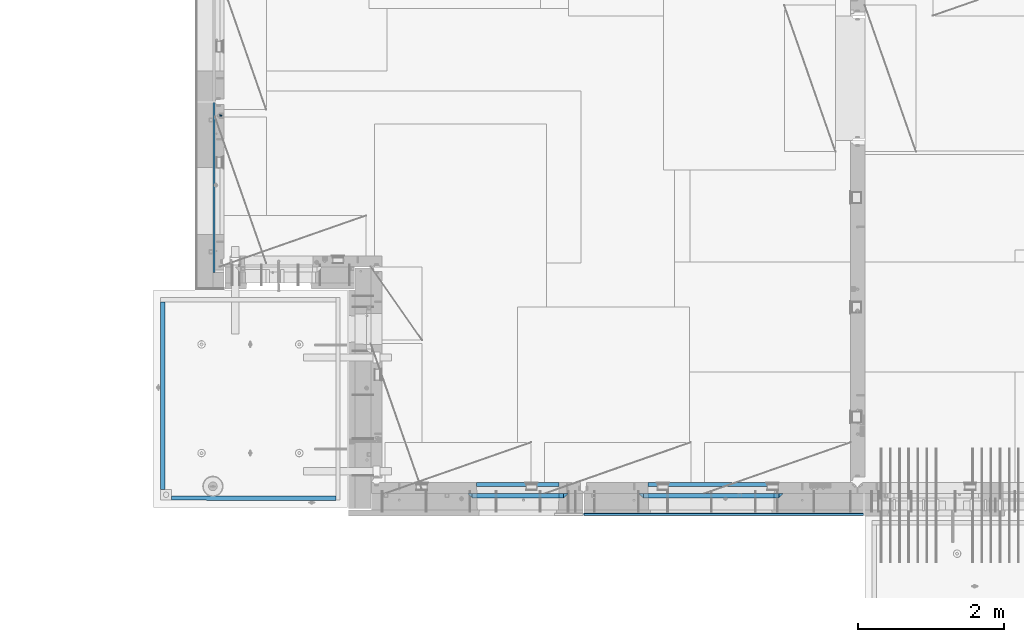
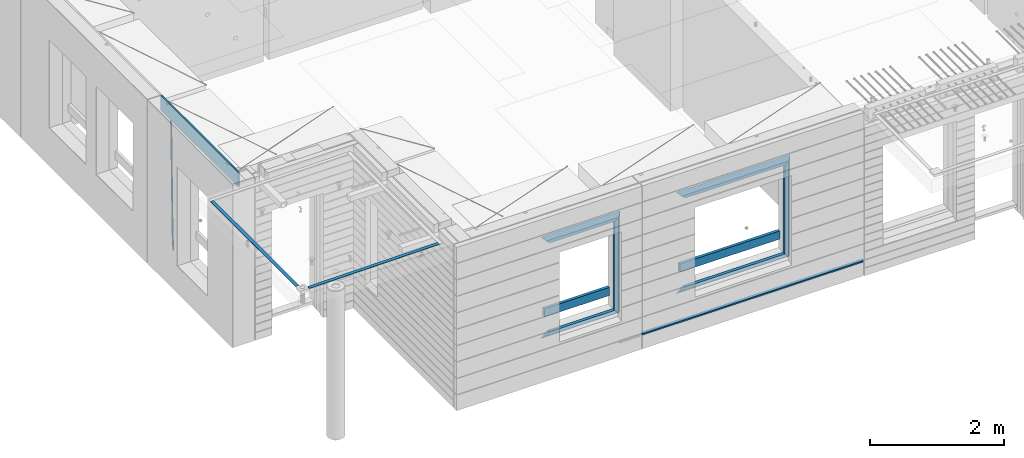
# One storey, part 92 of 350: 19 beams, 4 elements without a shape of their own.
"""IFC2X3 building model written with IfcOpenShell, lengths in millimetres."""

from ifc_helpers import new_model, si_unit, frame, origin_with_axes, place, context, subcontext, project, spatial, faceted_brep, material, type_object, element, aggregate, save


model = new_model("IFC2X3")

# Units and contexts
model_context = context("Model", 3, precision=1e-05, world=origin_with_axes())
body_context = subcontext(model_context, "Body", "Model", "MODEL_VIEW")
ifc_project = project(units=[si_unit("LENGTHUNIT", "METRE", prefix="MILLI"), si_unit("AREAUNIT", "SQUARE_METRE"), si_unit("VOLUMEUNIT", "CUBIC_METRE"), si_unit("MASSUNIT", "GRAM", prefix="KILO"), si_unit("TIMEUNIT", "SECOND"), si_unit("PLANEANGLEUNIT", "RADIAN"), si_unit("SOLIDANGLEUNIT", "STERADIAN"), si_unit("THERMODYNAMICTEMPERATUREUNIT", "DEGREE_CELSIUS"), si_unit("LUMINOUSINTENSITYUNIT", "LUMEN")], contexts=[model_context])

# Site, building, storey
site_placement = place(None, origin_with_axes())
site = spatial("IfcSite", under=ifc_project, at=site_placement, CompositionType="ELEMENT")
building_placement = place(site_placement, origin_with_axes())
building = spatial("IfcBuilding", under=site, at=building_placement, CompositionType="ELEMENT")
storey_placement = place(building_placement, origin_with_axes())
storey = spatial("IfcBuildingStorey", under=building, at=storey_placement, Name="2", CompositionType="ELEMENT", Elevation=0.0)

# Assembly, beam
assembly_1_placement = place(storey_placement, origin_with_axes())
assembly_1 = element("IfcElementAssembly", 1, at=assembly_1_placement, inside=storey, AssemblyPlace="NOTDEFINED", PredefinedType="REINFORCEMENT_UNIT")
ifc_material_1 = material()
beam_type_1 = type_object("IfcBeamType", Name="D20", PredefinedType="NOTDEFINED")
beam_1_placement = place(assembly_1_placement, frame((7964.99972837123, 13015.0021274634, 84990.0), z_axis=(-0.999642804636942, -0.000205726999925762, -0.0267249099902983), x_axis=(-0.0267249099948371, 4.30000201934385e-08, 0.999642825806181)))
beam_1 = element("IfcBeam", 2, at=beam_1_placement, type_object=beam_type_1, material=ifc_material_1, Name="JM20", ObjectType="D20", context=body_context, shape_type="Brep", body=[
    faceted_brep([(0.0, -10.0, 0.0), (-4.19531716033816e-08, -7.07106781186667, -7.07106781187031), (60.4266690400545, -7.0710677960451, -7.07106780570757), (60.4266690441291, -9.99999998418934, 6.15546014159918e-09), (0.0, 0.0, -10.0), (60.426669036824, 1.58106558956206e-08, -9.99999999384454), (4.196772351861e-08, 7.07106781186303, -7.07106781186667), (60.4266690363438, 7.07106782768096, -7.07106780570757), (0.0, 10.0, 0.0), (60.4266690388904, 10.0000000158179, 6.15182216279209e-09), (4.196772351861e-08, 7.07106781185939, 7.07106781185939), (60.4266690429649, 7.07106782768096, 7.07106781802577), (0.0, 0.0, 10.0), (60.4266690461809, 1.58179318532348e-08, 10.0000000061555), (-4.19531716033816e-08, -7.07106781187031, 7.07106781185939), (60.4266690466611, -7.07106779605238, 7.07106781802213), (61.0378400410118, -7.07106779588503, -7.07106780564936), (60.991799419251, -9.99999998403655, 6.21366780251265e-09), (61.0569027789461, 1.5985278878361e-08, -9.99999999378269), (61.0378209396877, 7.07106782784831, -7.07106780564936), (60.9917724058905, 10.0000000159635, 6.21366780251265e-09), (60.9457317841297, 7.07106782781193, 7.0710678180767), (60.9266690461809, 1.59488990902901e-08, 10.0000000062028), (60.9457508854539, -7.07106779591413, 7.0710678180767), (61.6489592143771, -7.07106614513759, -7.06310863441468), (61.5568818710308, -9.9999984576425, 0.00735959856683621), (61.6870830769039, 1.71821739058942e-06, -9.99179257185824), (61.6489210170112, 7.07106947854481, -7.06310888312146), (61.556827851804, 10.0000015422847, 0.00735924683976918), (61.4647505084577, 7.07106922979438, 7.07782747982128), (61.4266266459163, 1.36643211590126e-06, 10.0065114172685), (61.464788705809, -7.07106639389531, 7.07782772852806), (176.543135720174, -7.07075579406956, -5.56673531796696), (176.451058376813, -9.99968810657447, 1.50373291501455), (176.581259582701, 0.000312069292704109, -8.49541925541052), (176.543097522794, 7.07137982961285, -5.56673556667374), (176.451004357587, 10.00031189336, 1.50373256329476), (176.35892701424, 7.07137958085514, 8.57420079627263), (176.320803151699, 0.000311717507429421, 11.5028847337162), (176.358965211621, -7.07075604281999, 8.57420104497578), (177.098753836006, -7.07075429323595, -5.55949898843028), (176.98362511232, -9.99968666800123, 1.510669025065), (177.146421932586, 0.000313595905026887, -8.48805862247536), (177.098706077581, 7.07138133041735, -5.55949936166144), (176.983557571715, 10.0003133318824, 1.51066849724157), (176.868428848029, 7.07138095712435, 8.58083651073321), (176.820760751449, 0.000313067976094317, 11.5093961447819), (176.868476606425, -7.07075466652896, 8.58083688396073), (177.654312950661, -7.07075204110879, -5.54863964998367), (177.516135294456, -9.99968450931192, 1.52107783331303), (177.711524267797, 0.000315886711177882, -8.47701274570863), (177.654255632195, 7.07138358250813, -5.54864021007961), (177.516054233929, 10.0003154905207, 1.5210770412159), (177.377876577739, 7.0713830223176, 8.59079452451624), (177.320665260588, 0.000315094497636892, 11.5191676202448), (177.377933896176, -7.07075260129932, 8.59079508461218), (299.436796249574, -7.07025836271714, -3.1681962331204), (299.298618593355, -9.99919083092027, 3.90152125031091), (299.494007566798, 0.000809565110102994, -6.09656932889993), (299.436738931283, 7.07187726089978, -3.16819679320906), (299.298537533061, 10.0008091689197, 3.90152045822106), (299.160359876842, 7.07187670072017, 10.9712379416487), (299.103148559603, 0.000808772889286047, 13.8996110374392), (299.160417195119, -7.07025892290039, 10.9712385017483), (299.98743051647, -7.07025613056248, -3.15743315966392), (299.971788958996, -9.99918809853989, 3.91467979818117), (299.993912075952, 0.000811591617093654, -6.08679785393178), (299.987423933868, 7.07187949325817, -3.1574327280432), (299.971753863239, 10.0008119014747, 3.91467990454839), (299.95611230444, 7.07187992653053, 10.9867922621015), (299.949630744944, 0.000812204350950196, 13.9161569563694), (299.956118887014, -7.07025569729012, 10.9867918304735), (300.538107039494, -7.07025785017686, -3.16575821840888), (300.644985195438, -9.99919020432935, 3.90450175465594), (300.493854948218, 0.000810030429420294, -6.09435592770024), (300.538151196495, 7.071877773491, -3.16575855385963), (300.645047642858, 10.0008097955724, 3.90450128024895), (300.751925798773, 7.07187744142357, 10.9747612533101), (300.796177890064, 0.000809560813650023, 13.9033589625978), (300.751881641787, -7.07025818224065, 10.9747615887682), (2293.36490490142, -7.07648090940347, -33.2930642912361), (2293.47178305736, -10.0054132635523, -26.2228043181785), (2293.32065281013, -0.00541302880083094, -36.2216620005347), (2293.36494905842, 7.06565471425711, -33.2930646266868), (2293.47184550477, 9.99458673634581, -26.2228047925819), (2293.57872366071, 7.06565438219332, -19.1525448195243), (2293.62297575199, -0.00541349841296324, -16.2239471102366), (2293.57867950371, -7.0764812414709, -19.1525444840736), (2294.0658245362, -7.07648309818615, -33.3036607065333), (2294.05312277409, -10.0054150789219, -26.2315929392535), (2294.10928714235, -0.00541549149056664, -36.2335844756526), (2294.15805078732, 7.06565223761572, -33.3050546393533), (2294.18355038921, 9.99458451388637, -26.2335642579346), (2294.17084862708, 7.06565253314329, -19.1614964906439), (2294.12738602093, -0.00541507354500936, -16.2315727215355), (2294.07862237596, -7.07648280265857, -19.1601025578348), (2294.76670261032, -7.08562269121467, -33.294332712383), (2294.63442802057, -10.0129954178956, -26.2238563411993), (2294.89787471293, -0.0156988342423574, -36.2230891548279), (2294.95110548967, 7.05531064255774, -33.2944998654275), (2294.89521307347, 9.98530428734011, -26.2240927312887), (2294.76293848372, 7.0579315606592, -19.1536163601049), (2294.63176638114, -0.0119922963167483, -16.2248599176673), (2294.57853560438, -7.08300177311321, -19.1534492070678), (2316.52657204497, -7.36937582653991, -33.0047303660212), (2316.39429745522, -10.2967485532172, -25.9342539948302), (2316.65774414754, -0.299451969567599, -35.9334868084661), (2316.7109749243, 6.7715575072325, -33.0048975190657), (2316.65508250811, 9.70155115201487, -25.9344903849269), (2316.52280791836, 6.7741784253376, -18.8640140137468), (2316.39163581574, -0.295745431634714, -15.9352575713092), (2316.33840503903, -7.36675490843481, -18.863846860706), (2317.16202064224, -7.37766220584308, -32.9962731735213), (2317.05438744847, -10.3053562613532, -25.9254688497131), (2317.23607125619, -0.306993473008333, -35.925789846493), (2317.23316144495, 6.76474808850253, -32.9979477328052), (2317.15499573652, 9.6950321815566, -25.9278370341635), (2317.04736254275, 6.7673381260538, -18.8570327103698), (2316.97331192881, -0.303330606784584, -15.9275160373909), (2316.97622174003, -7.37507216829545, -18.8553581510787), (2317.79752306276, -7.37578610372293, -32.9880110666527), (2317.71453320107, -10.3033876998124, -25.9168792378296), (2317.81444760226, -0.305295583297266, -35.918287695793), (2317.75539265381, 6.76628640723357, -32.9911928173897), (2317.65495180529, 9.69652304524061, -25.9213789128698), (2317.5719619436, 6.76892144914746, -18.8502470840467), (2317.55503740412, -0.301569071270933, -15.9199704549137), (2317.61409235255, -7.3731510618054, -18.847065333317), (2417.8183084176, -7.07752398473531, -31.6906369377139), (2417.73531855589, -10.0051255808248, -24.6195051088798), (2417.83523295709, -0.007033464313281, -34.6209135668432), (2417.77617800863, 7.06454852621755, -31.6938186884508), (2417.67573716014, 9.99478516423187, -24.6240047839383), (2417.59274729842, 7.06718356813872, -17.5528729551006), (2417.57582275895, -0.00330695228694822, -14.6225963259749), (2417.6348777074, -7.07488894281778, -17.5496912043673)], [[[0, 1, 2, 3]], [[1, 4, 5, 2]], [[4, 6, 7, 5]], [[6, 8, 9, 7]], [[8, 10, 11, 9]], [[10, 12, 13, 11]], [[12, 14, 15, 13]], [[14, 0, 3, 15]], [[14, 12, 10, 8, 6, 4, 1, 0]], [[3, 2, 16, 17]], [[2, 5, 18, 16]], [[5, 7, 19, 18]], [[7, 9, 20, 19]], [[9, 11, 21, 20]], [[11, 13, 22, 21]], [[13, 15, 23, 22]], [[15, 3, 17, 23]], [[17, 16, 24, 25]], [[16, 18, 26, 24]], [[18, 19, 27, 26]], [[19, 20, 28, 27]], [[20, 21, 29, 28]], [[21, 22, 30, 29]], [[22, 23, 31, 30]], [[23, 17, 25, 31]], [[25, 24, 32, 33]], [[24, 26, 34, 32]], [[26, 27, 35, 34]], [[27, 28, 36, 35]], [[28, 29, 37, 36]], [[29, 30, 38, 37]], [[30, 31, 39, 38]], [[31, 25, 33, 39]], [[33, 32, 40, 41]], [[32, 34, 42, 40]], [[34, 35, 43, 42]], [[35, 36, 44, 43]], [[36, 37, 45, 44]], [[37, 38, 46, 45]], [[38, 39, 47, 46]], [[39, 33, 41, 47]], [[41, 40, 48, 49]], [[40, 42, 50, 48]], [[42, 43, 51, 50]], [[43, 44, 52, 51]], [[44, 45, 53, 52]], [[45, 46, 54, 53]], [[46, 47, 55, 54]], [[47, 41, 49, 55]], [[49, 48, 56, 57]], [[48, 50, 58, 56]], [[50, 51, 59, 58]], [[51, 52, 60, 59]], [[52, 53, 61, 60]], [[53, 54, 62, 61]], [[54, 55, 63, 62]], [[55, 49, 57, 63]], [[57, 56, 64, 65]], [[56, 58, 66, 64]], [[58, 59, 67, 66]], [[59, 60, 68, 67]], [[60, 61, 69, 68]], [[61, 62, 70, 69]], [[62, 63, 71, 70]], [[63, 57, 65, 71]], [[65, 64, 72, 73]], [[64, 66, 74, 72]], [[66, 67, 75, 74]], [[67, 68, 76, 75]], [[68, 69, 77, 76]], [[69, 70, 78, 77]], [[70, 71, 79, 78]], [[71, 65, 73, 79]], [[73, 72, 80, 81]], [[72, 74, 82, 80]], [[74, 75, 83, 82]], [[75, 76, 84, 83]], [[76, 77, 85, 84]], [[77, 78, 86, 85]], [[78, 79, 87, 86]], [[79, 73, 81, 87]], [[81, 80, 88, 89]], [[80, 82, 90, 88]], [[82, 83, 91, 90]], [[83, 84, 92, 91]], [[84, 85, 93, 92]], [[85, 86, 94, 93]], [[86, 87, 95, 94]], [[87, 81, 89, 95]], [[89, 88, 96, 97]], [[88, 90, 98, 96]], [[90, 91, 99, 98]], [[91, 92, 100, 99]], [[92, 93, 101, 100]], [[93, 94, 102, 101]], [[94, 95, 103, 102]], [[95, 89, 97, 103]], [[97, 96, 104, 105]], [[96, 98, 106, 104]], [[98, 99, 107, 106]], [[99, 100, 108, 107]], [[100, 101, 109, 108]], [[101, 102, 110, 109]], [[102, 103, 111, 110]], [[103, 97, 105, 111]], [[105, 104, 112, 113]], [[104, 106, 114, 112]], [[106, 107, 115, 114]], [[107, 108, 116, 115]], [[108, 109, 117, 116]], [[109, 110, 118, 117]], [[110, 111, 119, 118]], [[111, 105, 113, 119]], [[113, 112, 120, 121]], [[112, 114, 122, 120]], [[114, 115, 123, 122]], [[115, 116, 124, 123]], [[116, 117, 125, 124]], [[117, 118, 126, 125]], [[118, 119, 127, 126]], [[119, 113, 121, 127]], [[121, 120, 128, 129]], [[120, 122, 130, 128]], [[122, 123, 131, 130]], [[123, 124, 132, 131]], [[124, 125, 133, 132]], [[125, 126, 134, 133]], [[126, 127, 135, 134]], [[127, 121, 129, 135]], [[130, 131, 132, 133, 134, 135, 129, 128]]]),
])

assembly_2_placement = place(storey_placement, origin_with_axes())
assembly_2 = element("IfcElementAssembly", 3, at=assembly_2_placement, inside=storey, AssemblyPlace="NOTDEFINED", PredefinedType="REINFORCEMENT_UNIT")
ifc_material_2 = material(Name="TIMBER/T24")
beam_type_2 = type_object("IfcBeamType", PredefinedType="NOTDEFINED")
beam_2_placement = place(assembly_2_placement, frame((12920.0, 7567.5, 85029.4999998893), z_axis=(0.0, 1.0, 0.0), x_axis=(1.0, 0.0, 0.0)))
beam_2 = element("IfcBeam", 4, at=beam_2_placement, type_object=beam_type_2, material=ifc_material_2, context=body_context, shape_type="Brep", body=[
    faceted_brep([(0.0, 25.0, -12.5), (0.0, 25.0, 12.5), (3820.0, 25.0, 12.5), (3820.0, 25.0, -12.5), (3820.0, -25.0, 12.5), (3820.0, -1.45519152283669e-11, -12.5), (-1.45519152283669e-11, -3.63797880709171e-12, -12.5), (0.0, -25.0, 12.5)], [[[0, 1, 2, 3]], [[3, 2, 4, 5]], [[0, 3, 5, 6]], [[1, 0, 6, 7]], [[2, 1, 7, 4]], [[6, 5, 4, 7]]]),
])

assembly_3_placement = place(storey_placement, origin_with_axes())
assembly_3 = element("IfcElementAssembly", 5, at=assembly_3_placement, inside=storey, AssemblyPlace="NOTDEFINED", PredefinedType="REINFORCEMENT_UNIT")
beam_type_3 = type_object("IfcBeamType", PredefinedType="NOTDEFINED")
beam_3_placement = place(assembly_3_placement, frame((11453.0009023501, 7974.99972412935, 85685.0), z_axis=(0.0, 0.0, 1.0), x_axis=(1.0, 0.0, 0.0)))
beam_3 = element("IfcBeam", 6, at=beam_3_placement, type_object=beam_type_3, material=ifc_material_2, context=body_context, shape_type="Brep", body=[
    faceted_brep([(-3.63797880709171e-12, 24.9999999999964, -75.0), (-3.63797880709171e-12, 24.9999999999964, 75.0), (1130.0, 25.0, 75.0), (1130.0, 25.0, -75.0), (0.0, -25.0000000000073, 75.0), (1130.0, -25.0, 75.0), (0.0, -25.0000000000073, -75.0), (1130.0, -25.0, -75.0)], [[[0, 1, 2, 3]], [[1, 4, 5, 2]], [[4, 6, 7, 5]], [[6, 0, 3, 7]], [[5, 7, 3, 2]], [[6, 4, 1, 0]]]),
])

# Beam
beam_4_placement = place(assembly_2_placement, frame((13795.0009023501, 7974.99972412935, 85685.0), z_axis=(0.0, 0.0, 1.0), x_axis=(1.0, 0.0, 0.0)))
beam_4 = element("IfcBeam", 7, at=beam_4_placement, type_object=beam_type_3, material=ifc_material_2, context=body_context, shape_type="Brep", body=[
    faceted_brep([(-3.63797880709171e-12, 24.9999999999964, -75.0), (-3.63797880709171e-12, 24.9999999999964, 75.0), (1730.0, 25.0, 75.0), (1730.0, 25.0, -75.0), (0.0, -25.0000000000073, 75.0), (1730.0, -25.0, 75.0), (0.0, -25.0000000000073, -75.0), (1730.0, -25.0, -75.0)], [[[0, 1, 2, 3]], [[1, 4, 5, 2]], [[4, 6, 7, 5]], [[6, 0, 3, 7]], [[5, 7, 3, 2]], [[6, 4, 1, 0]]]),
])

# Assembly, beams
assembly_4_placement = place(storey_placement, origin_with_axes())
assembly_4 = element("IfcElementAssembly", 8, at=assembly_4_placement, inside=storey, AssemblyPlace="NOTDEFINED", PredefinedType="REINFORCEMENT_UNIT")
ifc_material_3 = material(Name="CONCRETE/Concrete_Undefined")
beam_type_4 = type_object("IfcBeamType", PredefinedType="NOTDEFINED")
beam_5_placement = place(assembly_4_placement, frame((7164.89422591706, 10470.0076633258, 87701.6030105556), z_axis=(0.0, -1.17599999975856e-06, 0.999999999999309), x_axis=(4.13430000058061e-05, -0.999999999144687, -1.176000002514e-06)))
beam_5 = element("IfcBeam", 9, at=beam_5_placement, type_object=beam_type_4, material=ifc_material_3, context=body_context, shape_type="Brep", body=[
    faceted_brep([(2.5465851649642e-11, 29.9999999999982, -4.99999999998545), (-2.91038304567337e-11, 29.9999999999982, 5.0), (2560.00574992944, 30.0000000000009, 5.00000000001455), (2560.00574992944, 30.0, -5.0), (-2.5465851649642e-11, -30.0000000000018, 5.0), (2560.00574992944, -29.9999999999991, 5.00000000001455), (2.72848410531878e-11, -30.0000000000018, -4.99999999998545), (2560.00574992944, -30.0, -5.0)], [[[0, 1, 2, 3]], [[1, 4, 5, 2]], [[4, 6, 7, 5]], [[6, 0, 3, 7]], [[5, 7, 3, 2]], [[6, 4, 1, 0]]]),
])
beam_6_placement = place(assembly_4_placement, frame((9529.67128970205, 7789.99860988154, 87725.2790473986), z_axis=(-0.00918361699724776, 4.9999998721906e-09, 0.999957829700257), x_axis=(-0.999957829700102, 5.55999999934641e-07, -0.00918361699724765)))
beam_6 = element("IfcBeam", 10, at=beam_6_placement, type_object=beam_type_4, material=ifc_material_3, context=body_context, shape_type="Brep", body=[
    faceted_brep([(2.5465851649642e-11, 29.9999999999982, -4.99999999998545), (-2.91038304567337e-11, 29.9999999999982, 5.0), (2244.79868782777, 30.0, 5.00000000001455), (2244.79868782778, 30.0, -4.99999999995634), (-2.5465851649642e-11, -30.0000000000018, 5.0), (2244.79868782778, -30.0000000000009, 5.00000000001455), (2.72848410531878e-11, -30.0000000000018, -4.99999999998545), (2244.79868782778, -30.0, -4.9999999999709)], [[[0, 1, 2, 3]], [[1, 4, 5, 2]], [[4, 6, 7, 5]], [[6, 0, 3, 7]], [[5, 7, 3, 2]], [[6, 4, 1, 0]]]),
])
aggregate(assembly_4, [beam_5, beam_6])

# Beam
ifc_material_4 = material(Name="CONCRETE/C25/30")
beam_type_5 = type_object("IfcBeamType", PredefinedType="NOTDEFINED")
beam_7_placement = place(assembly_3_placement, frame((11393.0000473781, 7820.0, 87085.0), z_axis=(0.0, 0.0, -1.0), x_axis=(1.0, 0.0, 0.0)))
beam_7 = element("IfcBeam", 11, at=beam_7_placement, type_object=beam_type_5, material=ifc_material_4, Name="SK", context=body_context, shape_type="Brep", body=[
    faceted_brep([(1185.94632735287, -29.9999988381387, 24.0540541168593), (1184.32470579405, 29.9999988381387, 25.6756756756804), (65.6760571454033, 29.9999988381387, 25.6756756756804), (64.0544355865859, -29.9999988381387, 24.0540541168593), (65.6760571454033, 29.9999988381387, 26.2937632551475), (64.0544355865859, -29.9999988381387, 24.9038019193104), (0.0, 30.0, -30.0), (0.0, -30.0, -30.0), (1250.00038146973, -29.9999988381387, -30.0), (1185.94632735287, -29.9999988381387, 24.9034749452549), (1184.32470579405, 29.9999988381387, 26.2934362810629), (1250.00038146973, 29.9999988381387, -30.0)], [[[0, 1, 2, 3]], [[3, 2, 4, 5]], [[5, 4, 6, 7]], [[0, 3, 5, 7, 8, 9]], [[1, 0, 9, 10]], [[6, 4, 2, 1, 10, 11]], [[7, 6, 11, 8]], [[8, 11, 10, 9]]]),
])

beam_8_placement = place(assembly_3_placement, frame((11333.0000473781, 7820.0, 87145.0), z_axis=(0.0, 0.0, -1.0), x_axis=(1.0, 0.0, 0.0)))
beam_8 = element("IfcBeam", 12, at=beam_8_placement, type_object=beam_type_5, material=ifc_material_4, Name="SK", context=body_context, shape_type="Brep", body=[
    faceted_brep([(60.0000000000073, 30.0, 30.0), (0.0, -30.0, -30.0), (60.0000000000073, -30.0, 30.0), (1370.00038146973, -30.0, -30.0), (1310.0003814697, -30.0, 30.0), (1310.0003814697, 30.0, 30.0)], [[[0, 1, 2]], [[2, 1, 3, 4]], [[0, 2, 4, 5]], [[1, 0, 5, 3]], [[3, 5, 4]]]),
])

beam_9_placement = place(assembly_3_placement, frame((12673.0004288479, 7820.0, 87175.0), z_axis=(-1.0, 3.00000001838171e-08, 0.0), x_axis=(0.0, 0.0, -1.0)))
beam_9 = element("IfcBeam", 13, at=beam_9_placement, type_object=beam_type_5, material=ifc_material_4, Name="SK", context=body_context, shape_type="Brep", body=[
    faceted_brep([(60.0000000000073, 30.0, 30.0), (0.0, -30.0, -30.0), (60.0000000000073, -30.0, 30.0), (1855.0, -30.0, -30.0), (1795.00000000001, -30.0, 30.0), (1795.00000000001, 30.0, 30.0)], [[[0, 1, 2]], [[3, 4, 2, 1]], [[4, 5, 0, 2]], [[5, 3, 1, 0]], [[4, 3, 5]]]),
])

beam_10_placement = place(assembly_3_placement, frame((12703.0004288479, 7820.0, 85350.0), z_axis=(0.0, 0.0, 1.0), x_axis=(-1.0, 3.00000001838171e-08, 0.0)))
beam_10 = element("IfcBeam", 14, at=beam_10_placement, type_object=beam_type_5, material=ifc_material_4, Name="SK", context=body_context, shape_type="Brep", body=[
    faceted_brep([(1370.00038146973, -30.0, -30.0), (1310.0003814697, 30.0, 30.0), (1310.0003814697, -30.0, 30.0), (0.0, -30.0, -30.0), (60.0000000000073, 30.0, 30.0), (60.0000000000073, -30.0, 30.0)], [[[0, 1, 2]], [[3, 4, 1, 0]], [[4, 5, 2, 1]], [[5, 3, 0, 2]], [[4, 3, 5]]]),
])

beam_11_placement = place(assembly_3_placement, frame((12643.0004288479, 7820.0, 85410.0), z_axis=(0.0, 0.0, 1.0), x_axis=(-1.0, 3.00000001838171e-08, 0.0)))
beam_11 = element("IfcBeam", 15, at=beam_11_placement, type_object=beam_type_5, material=ifc_material_4, Name="SK", context=body_context, shape_type="Brep", body=[
    faceted_brep([(1185.94594588314, -29.9999988381387, 24.0540541168593), (1184.32432432432, 29.9999988381387, 25.6756756756804), (65.6756756756768, 30.0, 25.6756756756804), (64.0540540540533, -30.0, 24.0540540540533), (1185.94594588314, -29.9999988381387, 24.9038019193104), (1184.32432432432, 29.9999988381387, 26.2937632551329), (1250.00038146973, -29.9999988381387, -30.0), (1250.00038146973, 29.9999988381387, -30.0), (0.0, -30.0, -30.0), (0.0, 30.0, -30.0), (65.6756756756768, 30.0, 26.293436281092), (64.0540540540533, -30.0, 24.9034748914419)], [[[0, 1, 2, 3]], [[1, 0, 4, 5]], [[4, 6, 7, 5]], [[8, 9, 7, 6]], [[2, 1, 5, 7, 9, 10]], [[3, 2, 10, 11]], [[6, 4, 0, 3, 11, 8]], [[8, 11, 10, 9]]]),
])

beam_12_placement = place(assembly_2_placement, frame((13675.0004364773, 7820.0, 87145.0), z_axis=(0.0, 0.0, -1.0), x_axis=(1.0, 0.0, 0.0)))
beam_12 = element("IfcBeam", 16, at=beam_12_placement, type_object=beam_type_5, material=ifc_material_4, Name="SK", context=body_context, shape_type="Brep", body=[
    faceted_brep([(60.0000000000073, 30.0, 30.0), (0.0, -30.0, -30.0), (60.0000000000073, -30.0, 30.0), (1969.99980926514, -30.0, -30.0), (1909.99980926512, -30.0, 30.0), (1909.99980926512, 30.0, 30.0)], [[[0, 1, 2]], [[2, 1, 3, 4]], [[0, 2, 4, 5]], [[1, 0, 5, 3]], [[4, 3, 5]]]),
])

beam_13_placement = place(assembly_2_placement, frame((13735.0004364773, 7820.0, 87085.0), z_axis=(0.0, 0.0, -1.0), x_axis=(1.0, 0.0, 0.0)))
beam_13 = element("IfcBeam", 17, at=beam_13_placement, type_object=beam_type_5, material=ifc_material_4, Name="SK", context=body_context, shape_type="Brep", body=[
    faceted_brep([(1785.94575521108, -30.0, 24.0540540540533), (1784.32413358946, 30.0, 25.6756756756804), (65.6754849408117, 30.0, 25.6756756756804), (64.05386331919, -30.0, 24.0540540540533), (65.6754849408117, 30.0, 26.2932727940788), (64.05386331919, -30.0, 24.9033114044141), (0.0, -30.0, -30.0), (0.0, 30.0, -30.0), (1849.99980926514, -30.0, -30.0), (1785.94575521108, -30.0, 24.9034748914273), (1784.32413358946, 30.0, 26.293436281092), (1849.99980926514, 30.0, -30.0)], [[[0, 1, 2, 3]], [[3, 2, 4, 5]], [[6, 5, 4, 7]], [[0, 3, 5, 6, 8, 9]], [[1, 0, 9, 10]], [[7, 4, 2, 1, 10, 11]], [[6, 7, 11, 8]], [[10, 9, 8, 11]]]),
])

beam_14_placement = place(assembly_2_placement, frame((15615.0002457424, 7820.0, 87175.0), z_axis=(-1.0, 3.00000001838171e-08, 0.0), x_axis=(0.0, 0.0, -1.0)))
beam_14 = element("IfcBeam", 18, at=beam_14_placement, type_object=beam_type_5, material=ifc_material_4, Name="SK", context=body_context, shape_type="Brep", body=[
    faceted_brep([(60.0000000000073, 30.0, 30.0), (0.0, -30.0, -30.0), (60.0000000000073, -30.0, 30.0), (1855.0, -30.0, -30.0), (1795.00000000001, -30.0, 30.0), (1795.00000000001, 30.0, 30.0)], [[[0, 1, 2]], [[3, 4, 2, 1]], [[4, 5, 0, 2]], [[5, 3, 1, 0]], [[4, 3, 5]]]),
])

beam_15_placement = place(assembly_2_placement, frame((15645.0002457424, 7820.0, 85350.0), z_axis=(0.0, 0.0, 1.0), x_axis=(-1.0, 3.00000001838171e-08, 0.0)))
beam_15 = element("IfcBeam", 19, at=beam_15_placement, type_object=beam_type_5, material=ifc_material_4, Name="SK", context=body_context, shape_type="Brep", body=[
    faceted_brep([(1909.99980926512, -30.0, 30.0), (1969.99980926514, -30.0, -30.0), (1909.99980926512, 30.0, 30.0), (0.0, -30.0, -30.0), (60.0000000000073, 30.0, 30.0), (60.0000000000073, -30.0, 30.0)], [[[0, 1, 2]], [[3, 4, 2, 1]], [[4, 5, 0, 2]], [[5, 3, 1, 0]], [[4, 3, 5]]]),
])

beam_16_placement = place(assembly_2_placement, frame((15585.0002457424, 7820.0, 85410.0), z_axis=(0.0, 0.0, 1.0), x_axis=(-1.0, 3.00000001838171e-08, 0.0)))
beam_16 = element("IfcBeam", 20, at=beam_16_placement, type_object=beam_type_5, material=ifc_material_4, Name="SK", context=body_context, shape_type="Brep", body=[
    faceted_brep([(1785.94594594595, -30.0, 24.0540540540533), (1784.32432432433, 30.0, 25.6756756756804), (65.6756756756768, 30.0, 25.6756756756804), (64.0540540540533, -30.0, 24.0540540540533), (1785.94594594595, -30.0, 24.9033114043996), (1784.32432432433, 30.0, 26.2932727940788), (1849.99980926514, -30.0, -30.0), (1849.99980926514, 30.0, -30.0), (0.0, -30.0, -30.0), (0.0, 30.0, -30.0), (65.6756756756768, 30.0, 26.293436281092), (64.0540540540533, -30.0, 24.9034748914419)], [[[0, 1, 2, 3]], [[1, 0, 4, 5]], [[6, 7, 5, 4]], [[8, 9, 7, 6]], [[2, 1, 5, 7, 9, 10]], [[3, 2, 10, 11]], [[6, 4, 0, 3, 11, 8]], [[8, 11, 10, 9]]]),
])

beam_type_6 = type_object("IfcBeamType", PredefinedType="NOTDEFINED")
beam_17_placement = place(assembly_3_placement, frame((12608.0004288479, 7820.0, 87115.0), z_axis=(-1.0, 3.00000001838171e-08, 0.0), x_axis=(0.0, 0.0, -1.0)))
beam_17 = element("IfcBeam", 21, at=beam_17_placement, type_object=beam_type_6, material=ifc_material_4, Name="SK", context=body_context, shape_type="Brep", body=[
    faceted_brep([(0.0, -30.0, -35.0), (54.9034748914273, -30.0, 29.0540540540533), (56.2934362811066, 30.0, 30.6756756756768), (0.0, 30.0, -35.0), (1735.0, -30.0, -35.0), (1680.09652510857, -30.0, 29.0540540540533), (1678.70656371891, 30.0, 30.6756756756768), (1735.0, 30.0, -35.0)], [[[0, 1, 2, 3]], [[1, 0, 4, 5]], [[2, 1, 5, 6]], [[3, 2, 6, 7]], [[7, 4, 0, 3]], [[4, 7, 6, 5]]]),
])

aggregate(assembly_3, [beam_3, beam_7, beam_8, beam_9, beam_17, beam_10, beam_11])

beam_18_placement = place(assembly_2_placement, frame((15550.0002457424, 7820.0, 87115.0), z_axis=(-1.0, 3.00000001838171e-08, 0.0), x_axis=(0.0, 0.0, -1.0)))
beam_18 = element("IfcBeam", 22, at=beam_18_placement, type_object=beam_type_6, material=ifc_material_4, Name="SK", context=body_context, shape_type="Brep", body=[
    faceted_brep([(0.0, -30.0, -35.0), (54.9034748914273, -30.0, 29.0540540540533), (56.2934362811066, 30.0, 30.6756756756768), (0.0, 30.0, -35.0), (1735.0, -30.0, -35.0), (1680.09652510857, -30.0, 29.0540540540533), (1678.70656371891, 30.0, 30.6756756756768), (1735.0, 30.0, -35.0)], [[[0, 1, 2, 3]], [[1, 0, 4, 5]], [[2, 1, 5, 6]], [[3, 2, 6, 7]], [[7, 4, 0, 3]], [[4, 7, 6, 5]]]),
])

aggregate(assembly_2, [beam_2, beam_12, beam_13, beam_14, beam_18, beam_15, beam_16, beam_4])

beam_type_7 = type_object("IfcBeamType", Name="270X30", PredefinedType="NOTDEFINED")
beam_19_placement = place(assembly_1_placement, frame((7864.99972556029, 13195.0003943318, 87605.0), z_axis=(0.0, 0.0, 1.0), x_axis=(0.0, -1.0, 0.0)))
beam_19 = element("IfcBeam", 23, at=beam_19_placement, type_object=beam_type_7, material=ifc_material_4, ObjectType="270X30", context=body_context, shape_type="Brep", body=[
    faceted_brep([(0.0, 15.0, -135.0), (0.0, 15.0, 135.0), (2320.00069431986, 15.0000000000009, 135.0), (2320.00069431986, 15.0000000000009, -135.0), (0.0, -15.0, 135.0), (2320.00069431986, -14.9999999999991, 135.0), (0.0, -15.0, -135.0), (2320.00069431986, -14.9999999999991, -135.0)], [[[0, 1, 2, 3]], [[1, 4, 5, 2]], [[4, 6, 7, 5]], [[6, 0, 3, 7]], [[5, 7, 3, 2]], [[6, 4, 1, 0]]]),
])

aggregate(assembly_1, [beam_1, beam_19])

save(model, "model.ifc")
